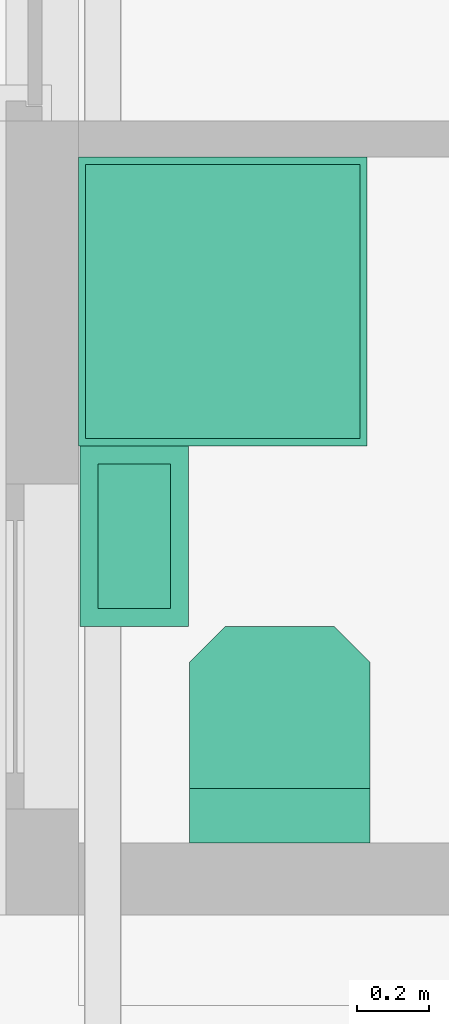
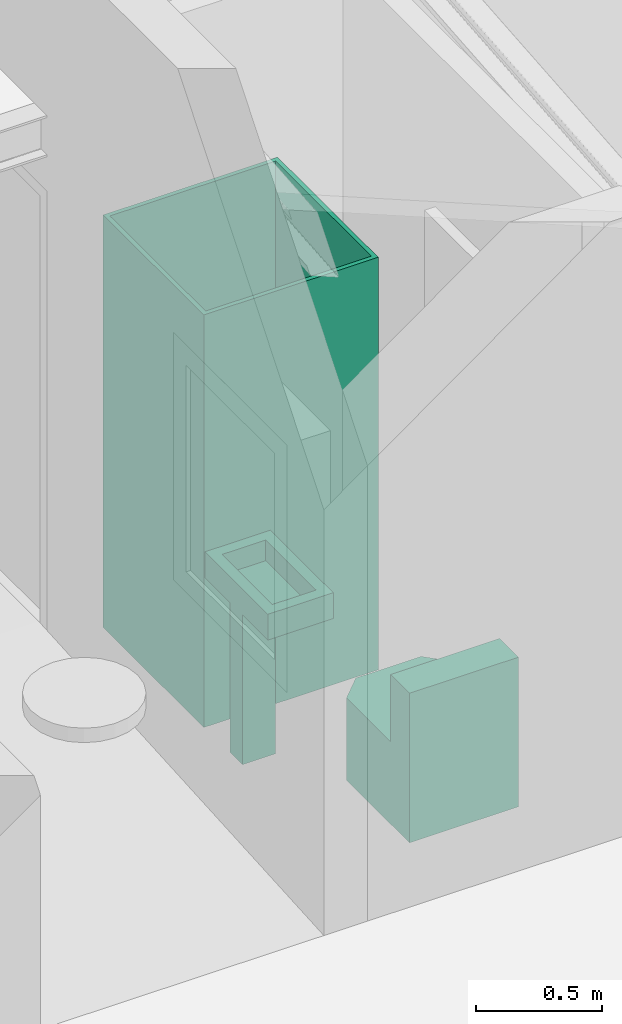
# Not in any storey, part 4 of 5: 3 sanitary terminals.
"""IFC4 model written with IfcOpenShell, lengths in millimetres."""

from ifc_helpers import new_model, entity, si_unit, converted_unit, frame, origin_with_axes, origin_2d_with_axis, place, context, subcontext, project, polygons, source, transform, mapped, type_object, type_shapes, element, save


model = new_model("IFC4")

# Units and contexts
model_context = context("Model", 3, precision=1e-05, world=origin_with_axes())
plan_context = context("Plan", 2, precision=1e-05, world=origin_2d_with_axis())
body_context = subcontext(model_context, "Body", "Model", "MODEL_VIEW")
ifc_project = project(units=[converted_unit("PLANEANGLEUNIT", "degree", entity("IfcReal", 0.0174532925199433), si_unit("PLANEANGLEUNIT", "RADIAN"), dimensions=[0, 0, 0, 0, 0, 0, 0]), si_unit("AREAUNIT", "SQUARE_METRE"), si_unit("VOLUMEUNIT", "CUBIC_METRE"), si_unit("LENGTHUNIT", "METRE", prefix="MILLI")], contexts=[model_context, plan_context])

# Sanitary terminals
sanitary_terminal_type_1 = type_object("IfcSanitaryTerminalType", Name="SHR", PredefinedType="SHOWER")
shared_shape_1 = source(origin_with_axes(), body_context, "Body", "Tessellation", [
    polygons([(-19.999979019165, -19.9999904632568, 1999.99975585938), (1.4901160284353e-05, 6.55670828564325e-06, 0.0), (-19.999979019165, -779.999938964844, 1999.99975585938), (1.4901160284353e-05, -799.999877929688, 0.0), (-779.999938964844, -19.9999980926514, 1999.99975585938), (-799.999877929688, 0.0, 0.0), (-779.999938964844, -779.999938964844, 1999.99975585938), (-799.999877929688, -799.999877929688, 0.0), (1.4901160284353e-05, -799.999877929688, 1999.99975585938), (-799.999877929688, -799.999877929688, 1999.99975585938), (1.4901160284353e-05, 6.55670828564325e-06, 1999.99975585938), (-799.999877929688, 0.0, 1999.99975585938), (-19.999979019165, -779.999938964844, 49.9999961853027), (-779.999938964844, -779.999938964844, 49.9999961853027), (-19.999979019165, -19.9999904632568, 49.9999961853027), (-779.999938964844, -19.9999980926514, 49.9999961853027)], [[[5, 7, 14, 16]], [[4, 9, 10, 8]], [[8, 10, 12, 6]], [[6, 2, 4, 8]], [[2, 11, 9, 4]], [[6, 12, 11, 2]], [[3, 7, 10, 9]], [[1, 3, 9, 11]], [[7, 5, 12, 10]], [[5, 1, 11, 12]], [[15, 16, 14, 13]], [[7, 3, 13, 14]], [[1, 5, 16, 15]], [[3, 1, 15, 13]]]),
])
type_shapes(sanitary_terminal_type_1, [shared_shape_1])
sanitary_terminal_1_placement = place(None, frame((200.000524520874, 2100.00109672546, 0.0), z_axis=(0.0, 0.0, 1.0), x_axis=(-4.37113882867379e-08, 0.999999999999999, 0.0)))
element("IfcSanitaryTerminal", 1, at=sanitary_terminal_1_placement, type_object=sanitary_terminal_type_1, Name="SanitaryTerminal", context=body_context, shape_type="MappedRepresentation", body=[
    mapped(shared_shape_1, transform((0.0, 0.0, 0.0), x_axis=(1.0, 0.0, 0.0), y_axis=(0.0, 1.0, 0.0), z_axis=(0.0, 0.0, 1.0), scale=1.0)),
])
sanitary_terminal_type_2 = type_object("IfcSanitaryTerminalType", Name="WC - Toilet - 600x500", PredefinedType="WCSEAT")
shared_shape_2 = source(origin_with_axes(), body_context, "Body", "Tessellation", [
    polygons([(150.0, 6.55670828564325e-06, 399.999847412109), (150.0, 6.55670828564325e-06, 0.0), (150.0, -499.999908447266, 399.999847412109), (150.0, -499.999908447266, 0.0), (-5.96046411374118e-05, 6.55670828564325e-06, 0.0), (-5.96046411374118e-05, -499.999908447266, 0.0), (-5.96046411374118e-05, -499.999908447266, 399.999847412109), (-5.96046411374118e-05, 6.55670828564325e-06, 399.999847412109), (150.0, -499.999908447266, 724.999877929688), (150.0, 6.55670828564325e-06, 724.999877929688), (-5.96046411374118e-05, -499.999908447266, 724.999877929688), (-5.96046411374118e-05, 6.55670828564325e-06, 724.999877929688), (599.999938964844, -99.9999923706055, 399.999847412109), (499.999938964844, -1.39081669203733e-06, 399.999847412109), (499.999938964844, -1.39081669203733e-06, 0.0), (599.999938964844, -100.0, 0.0), (499.999938964844, -499.999908447266, 399.999847412109), (599.999938964844, -399.999908447266, 399.999847412109), (599.999938964844, -399.999908447266, 0.0), (499.999938964844, -499.999908447266, 0.0)], [[[13, 14, 1, 3, 17, 18]], [[2, 4, 6, 5]], [[2, 15, 16, 19, 20, 4]], [[20, 17, 3, 4]], [[6, 7, 8, 5]], [[3, 1, 10, 9]], [[1, 2, 5, 8]], [[4, 3, 7, 6]], [[9, 10, 12, 11]], [[1, 8, 12, 10]], [[7, 3, 9, 11]], [[8, 7, 11, 12]], [[13, 16, 15, 14]], [[2, 1, 14, 15]], [[17, 20, 19, 18]], [[16, 13, 18, 19]]]),
])
type_shapes(sanitary_terminal_type_2, [shared_shape_2])
sanitary_terminal_2_placement = place(None, frame((508.108854293823, 200.327649712563, -0.000149011611938477), z_axis=(0.0, 0.0, 1.0), x_axis=(7.54979012640431e-08, 0.999999999999997, 0.0)))
element("IfcSanitaryTerminal", 2, at=sanitary_terminal_2_placement, type_object=sanitary_terminal_type_2, Name="SanitaryTerminal", context=body_context, shape_type="MappedRepresentation", body=[
    mapped(shared_shape_2, transform((0.0, 0.0, 0.0), x_axis=(1.0, 0.0, 0.0), y_axis=(0.0, 1.0, 0.0), z_axis=(0.0, 0.0, 1.0), scale=1.0)),
])
sanitary_terminal_type_3 = type_object("IfcSanitaryTerminalType", Name="WHB_500x300", PredefinedType="WASHHANDBASIN")
shared_shape_3 = source(origin_with_axes(), body_context, "Body", "Tessellation", [
    polygons([(-49.9999656677246, -50.0000076293945, 849.999877929688), (-49.9999656677246, -449.999938964844, 849.999877929688), (-249.999908447266, -49.9999961853027, 849.999877929688), (-249.999908447266, -449.999938964844, 849.999877929688), (-149.999984741211, -200.000030517578, 3.85374079314715e-07), (2.98023205687059e-05, -499.999938964844, 849.999877929688), (-299.999908447266, -499.999908447266, 849.999877929688), (2.98023205687059e-05, -1.5298986909329e-05, 849.999877929688), (-299.999908447266, 0.0, 849.999877929688), (-49.9999656677246, -449.999938964844, 749.999816894531), (-249.999908447266, -449.999938964844, 749.999816894531), (-49.9999656677246, -50.0000076293945, 749.999816894531), (-249.999908447266, -49.9999961853027, 749.999816894531), (2.98023205687059e-05, -1.5298986909329e-05, 724.999877929688), (-299.999908447266, -499.999908447266, 724.999877929688), (2.98023205687059e-05, -499.999938964844, 724.999877929688), (-299.999908447266, 0.0, 724.999877929688), (-49.9999694824219, -1.5298986909329e-05, 724.999877929688), (-299.999877929688, -299.999908447266, 0.0), (-49.9999694824219, -499.999938964844, 724.999877929688), (-149.999938964844, -300.0, 3.85374079314715e-07), (-49.9999809265137, -200.0, 724.999877929688), (-299.999908447266, -199.999984741211, 724.999877929688), (-299.999877929688, -274.999908447266, 724.999877929688), (-299.999908447266, -225.0, 724.999877929688), (-299.999877929688, -299.999908447266, 724.999877929688), (-49.9999504089355, -299.999969482422, 724.999877929688), (-299.999908447266, -199.999984741211, 0.0), (-149.999984741211, -200.000030517578, 724.999877929688), (-149.999938964844, -300.0, 724.999877929688), (-149.999984741211, -225.000045776367, 724.999877929688), (-149.999938964844, -275.0, 724.999877929688)], [[[3, 4, 11, 13]], [[16, 6, 7, 15, 20]], [[15, 7, 9, 17, 23, 25, 24, 26]], [[21, 19, 28, 5]], [[14, 8, 6, 16]], [[17, 9, 8, 14, 18]], [[2, 4, 7, 6]], [[1, 2, 6, 8]], [[4, 3, 9, 7]], [[3, 1, 8, 9]], [[12, 13, 11, 10]], [[4, 2, 10, 11]], [[1, 3, 13, 12]], [[2, 1, 12, 10]], [[14, 16, 20, 27, 32, 31, 22, 18]], [[27, 30, 32]], [[24, 25, 23, 28, 19, 26]], [[31, 32, 30, 21, 5, 29]], [[20, 15, 26, 30, 27]], [[17, 18, 22, 29, 23]], [[22, 31, 29]], [[30, 26, 19, 21]], [[28, 23, 29, 5]]]),
])
type_shapes(sanitary_terminal_type_3, [shared_shape_3])
sanitary_terminal_3_placement = place(None, frame((505.01948595047, 1300.25684833527, -2.98023223876953e-05), z_axis=(0.0, 0.0, 1.0), x_axis=(1.0, 0.0, 0.0)))
element("IfcSanitaryTerminal", 3, at=sanitary_terminal_3_placement, type_object=sanitary_terminal_type_3, Name="SanitaryTerminal", context=body_context, shape_type="MappedRepresentation", body=[
    mapped(shared_shape_3, transform((0.0, 0.0, 0.0), x_axis=(1.0, 0.0, 0.0), y_axis=(0.0, 1.0, 0.0), z_axis=(0.0, 0.0, 1.0), scale=1.0)),
])

save(model, "model.ifc")
